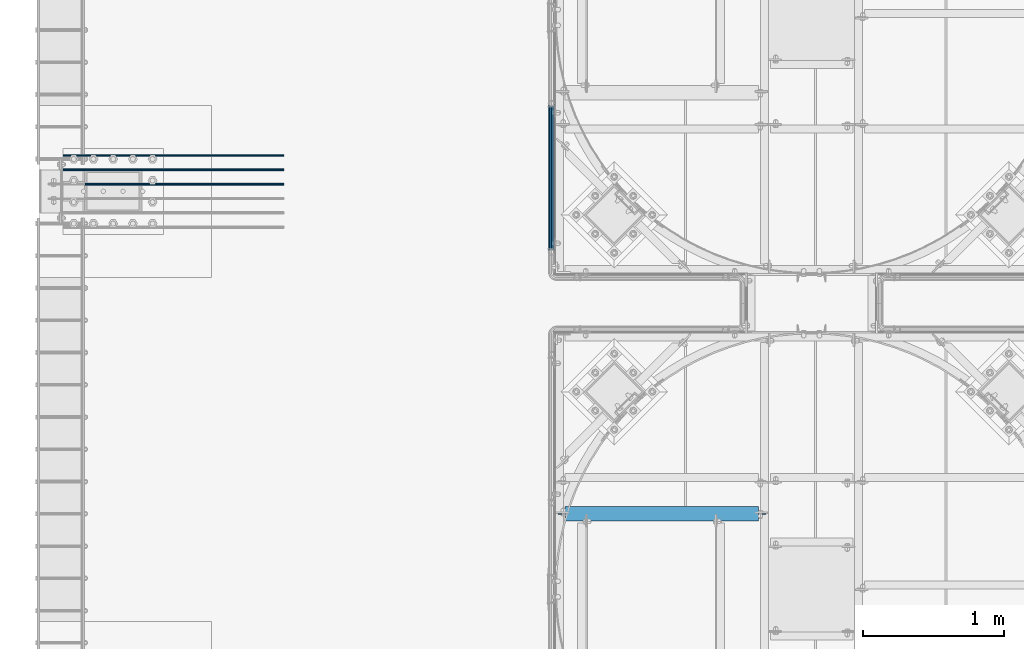
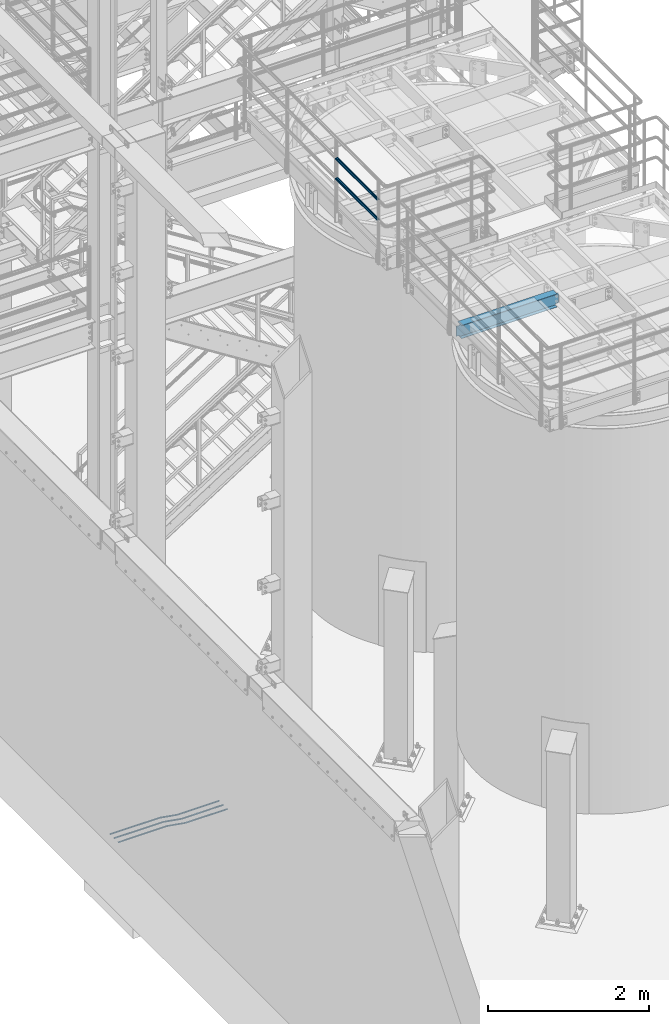
# One storey, part 918 of 1876: 6 beams, 3 elements without a shape of their own.
"""IFC2X3 building model written with IfcOpenShell, lengths in millimetres."""

import ifcopenshell
import ifcopenshell.guid

model = None  # the IFC model being written
_history = None  # IfcOwnerHistory: only IFC2X3 demands one
_inside = {}  # id of a spatial element -> (the spatial element, [elements in it])
_under = {}  # id of a project, library or spatial element -> (it, [spatial elements below it])
_declared = {}  # id of a project -> (the project, [libraries it declares])
_typed = {}  # id of a type object -> (the type object, [elements of that type])
_made_of = {}  # id of a material, layer set ... -> (it, [elements and type objects made of it])


def new_model(schema):
    """Start an empty IFC model of exactly this schema.

    Asked for "IFC4X3", IfcOpenShell would pick the latest addendum, in which some entities
    have other attributes; the version numbers below select the first issue.
    IFC2X3 requires an IfcOwnerHistory on every rooted entity: one is made here for all.
    """
    global model, _history
    if schema == "IFC4X3":
        model = ifcopenshell.file(schema_version=(4, 3, 0, 0))
    else:
        model = ifcopenshell.file(schema=schema)
    _inside.clear()
    _under.clear()
    _declared.clear()
    _typed.clear()
    _made_of.clear()
    _history = None
    if model.schema == "IFC2X3":
        org = make("IfcOrganization", Name="unknown")
        user = make(
            "IfcPersonAndOrganization",
            ThePerson=make("IfcPerson", FamilyName="unknown"),
            TheOrganization=org,
        )
        app = make(
            "IfcApplication",
            ApplicationDeveloper=org,
            Version="unknown",
            ApplicationFullName="unknown",
            ApplicationIdentifier="unknown",
        )
        _history = make(
            "IfcOwnerHistory",
            OwningUser=user,
            OwningApplication=app,
            ChangeAction="ADDED",
            CreationDate=0,
        )
    return model


def make(cls, **values):
    """One entity of the class cls with the attributes given. An attribute that is None is left unset."""
    return model.create_entity(
        cls, **{name: value for name, value in values.items() if value is not None}
    )


def rooted(cls, **values):
    """An entity with a GlobalId (a new one), such as an element, a storey or a relation."""
    return make(cls, GlobalId=ifcopenshell.guid.new(), OwnerHistory=_history, **values)


def si_unit(unit_type, name, prefix=None):
    """IfcSIUnit, for example si_unit("LENGTHUNIT", "METRE", prefix="MILLI")."""
    return make("IfcSIUnit", UnitType=unit_type, Prefix=prefix, Name=name)


def assignment(units):
    """IfcUnitAssignment: the units of a project."""
    return None if units is None else make("IfcUnitAssignment", Units=units)


def point(xyz):
    """IfcCartesianPoint."""
    return None if xyz is None else make("IfcCartesianPoint", Coordinates=xyz)


def direction(xyz):
    """IfcDirection."""
    return None if xyz is None else make("IfcDirection", DirectionRatios=xyz)


def frame(location, z_axis=None, x_axis=None):
    """IfcAxis2Placement3D, a coordinate frame: its origin and axes. An axis left out is left unset."""
    return make(
        "IfcAxis2Placement3D",
        Location=point(location),
        Axis=direction(z_axis),
        RefDirection=direction(x_axis),
    )


def origin_with_axes():
    """The frame at (0, 0, 0) with the z axis (0, 0, 1) and the x axis (1, 0, 0) written out."""
    return frame((0.0, 0.0, 0.0), z_axis=(0.0, 0.0, 1.0), x_axis=(1.0, 0.0, 0.0))


def place(relative_to, where):
    """IfcLocalPlacement: puts the frame where relative to a parent placement (None: the world)."""
    return make(
        "IfcLocalPlacement", PlacementRelTo=relative_to, RelativePlacement=where
    )


def context(
    kind, dimensions, precision=None, world=None, true_north=None, identifier=None
):
    """IfcGeometricRepresentationContext, for example the 3D "Model" context."""
    return make(
        "IfcGeometricRepresentationContext",
        ContextIdentifier=identifier,
        ContextType=kind,
        CoordinateSpaceDimension=dimensions,
        Precision=precision,
        WorldCoordinateSystem=world,
        TrueNorth=true_north,
    )


def subcontext(parent, identifier, kind, view, scale=None):
    """IfcGeometricRepresentationSubContext, for example "Body" below "Model"."""
    return make(
        "IfcGeometricRepresentationSubContext",
        ContextIdentifier=identifier,
        ContextType=kind,
        ParentContext=parent,
        TargetScale=scale,
        TargetView=view,
    )


def project(units=None, contexts=None):
    """IfcProject with its units and contexts."""
    return rooted(
        "IfcProject",
        Name="project",
        RepresentationContexts=contexts,
        UnitsInContext=assignment(units),
    )


def spatial(cls, under=None, at=None, **own):
    """A site, building, storey or space (cls), placed at a placement, below another one or the project."""
    s = rooted(cls, ObjectPlacement=at, **own)
    if under is not None:
        _under.setdefault(under.id(), (under, []))[1].append(s)
    return s


def faces_of(points, faces, orient=None, outer=None):
    """IfcFace entities. A face is a list of loops; a loop is a list of indices into points, from 0.

    orient and outer hold one flag for each loop. By default every Orientation is true, the
    first loop of a face is its IfcFaceOuterBound and the others are IfcFaceBound.
    """
    made = []
    for i, loops in enumerate(faces):
        bounds = []
        for j, loop in enumerate(loops):
            is_outer = j == 0 if outer is None else outer[i][j]
            bounds.append(
                make(
                    "IfcFaceOuterBound" if is_outer else "IfcFaceBound",
                    Bound=make("IfcPolyLoop", Polygon=[points[k] for k in loop]),
                    Orientation=True if orient is None else orient[i][j],
                )
            )
        made.append(make("IfcFace", Bounds=bounds))
    return made


def faceted_brep(points, faces, orient=None, outer=None, voids=None):
    """IfcFacetedBrep: a solid bounded by flat faces; with voids (closed shells), ...WithVoids."""
    shared = [point(p) for p in points]
    hull = make("IfcClosedShell", CfsFaces=faces_of(shared, faces, orient, outer))
    if voids is None:
        return make("IfcFacetedBrep", Outer=hull)
    return make(
        "IfcFacetedBrepWithVoids",
        Outer=hull,
        Voids=[
            make(cls, CfsFaces=faces_of(shared, fs, o, b)) for cls, fs, o, b in voids
        ],
    )


def shape(context_of_items, identifier, shape_type, items):
    """IfcShapeRepresentation: the items that make up one representation, for example the "Body"."""
    return make(
        "IfcShapeRepresentation",
        ContextOfItems=context_of_items,
        RepresentationIdentifier=identifier,
        RepresentationType=shape_type,
        Items=items,
    )


def material(Name=None, Category=None):
    """IfcMaterial."""
    return make("IfcMaterial", Name=Name, Category=Category)


def made_of(thing, what):
    """Note that an element or type object is made of a material, layer set ...; save() writes the relation."""
    if what is not None:
        _made_of.setdefault(what.id(), (what, []))[1].append(thing)
    return thing


def type_object(cls, material=None, **own):
    """A type object (cls), such as IfcWallType, which elements share."""
    return made_of(rooted(cls, **own), material)


def element(
    cls,
    number,
    at=None,
    inside=None,
    cuts=None,
    type_object=None,
    material=None,
    context=None,
    identifier="Body",
    shape_type=None,
    held_by="IfcProductDefinitionShape",
    body=None,
    shapes=None,
    **own,
):
    """One element of the class cls, such as IfcWall. Its Tag is "e" and its number.

    at: its placement. inside: the storey or other place that contains it. cuts: it is an
    opening in that element (IfcRelVoidsElement). A single representation is given by context,
    identifier, shape_type and body (its items); several are given by shapes. held_by: the class
    of the entity that holds the representations. save() writes the other relations.
    """
    e = rooted(cls, Tag="e%d" % number, ObjectPlacement=at, **own)
    if body is not None:
        shapes = [shape(context, identifier, shape_type, body)]
    if shapes is not None:
        e.Representation = make(held_by, Representations=shapes)
    if inside is not None:
        _inside.setdefault(inside.id(), (inside, []))[1].append(e)
    if cuts is not None:
        rooted(
            "IfcRelVoidsElement", RelatingBuildingElement=cuts, RelatedOpeningElement=e
        )
    if type_object is not None:
        _typed.setdefault(type_object.id(), (type_object, []))[1].append(e)
    return made_of(e, material)


def aggregate(whole, parts):
    """IfcRelAggregates: a whole, such as a stair, and the parts it consists of."""
    return rooted("IfcRelAggregates", RelatingObject=whole, RelatedObjects=parts)


def save(model, path):
    """Write the relations noted so far, then the file.

    IfcRelAggregates (storeys below a building ...), IfcRelContainedInSpatialStructure (elements
    in a storey), IfcRelDefinesByType, IfcRelAssociatesMaterial and IfcRelDeclares: one each for
    every whole, place, type object, material and project.
    """
    for whole, parts in _under.values():
        aggregate(whole, parts)
    for where, things in _inside.values():
        rooted(
            "IfcRelContainedInSpatialStructure",
            RelatedElements=things,
            RelatingStructure=where,
        )
    for kind, things in _typed.values():
        rooted("IfcRelDefinesByType", RelatedObjects=things, RelatingType=kind)
    for what, things in _made_of.values():
        rooted("IfcRelAssociatesMaterial", RelatedObjects=things, RelatingMaterial=what)
    for by, libraries in _declared.values():
        rooted("IfcRelDeclares", RelatingContext=by, RelatedDefinitions=libraries)
    model.write(path)


model = new_model("IFC2X3")

# Units and contexts
model_context = context("Model", 3, precision=1e-05, world=origin_with_axes())
body_context = subcontext(model_context, "Body", "Model", "MODEL_VIEW")
ifc_project = project(units=[si_unit("LENGTHUNIT", "METRE", prefix="MILLI"), si_unit("AREAUNIT", "SQUARE_METRE"), si_unit("VOLUMEUNIT", "CUBIC_METRE"), si_unit("MASSUNIT", "GRAM", prefix="KILO"), si_unit("TIMEUNIT", "SECOND"), si_unit("PLANEANGLEUNIT", "RADIAN"), si_unit("SOLIDANGLEUNIT", "STERADIAN"), si_unit("THERMODYNAMICTEMPERATUREUNIT", "DEGREE_CELSIUS"), si_unit("LUMINOUSINTENSITYUNIT", "LUMEN")], contexts=[model_context])

# Site, building, storey
site_placement = place(None, origin_with_axes())
site = spatial("IfcSite", under=ifc_project, at=site_placement, CompositionType="ELEMENT")
building_placement = place(site_placement, origin_with_axes())
building = spatial("IfcBuilding", under=site, at=building_placement, Name="Undefined", CompositionType="ELEMENT")
storey_placement = place(building_placement, origin_with_axes())
storey = spatial("IfcBuildingStorey", under=building, at=storey_placement, Name="Undefined", CompositionType="ELEMENT", Elevation=0.0)

# Assembly, beams
assembly_1_placement = place(storey_placement, origin_with_axes())
assembly_1 = element("IfcElementAssembly", 1, at=assembly_1_placement, inside=storey, Name="HANDRAIL", AssemblyPlace="NOTDEFINED", PredefinedType="RIGID_FRAME")
ifc_material_1 = material()
beam_type_1 = type_object("IfcBeamType", Name="PIPE1-1/4STD", PredefinedType="NOTDEFINED")
beam_1_placement = place(assembly_1_placement, frame((3338.07274593762, -11201.3643554687, 8480.425), z_axis=(0.0, 0.0, 1.0), x_axis=(0.0, 1.0, 0.0)))
beam_1 = element("IfcBeam", 2, at=beam_1_placement, type_object=beam_type_1, material=ifc_material_1, Name="RAIL", ObjectType="PIPE1-1/4STD", context=body_context, shape_type="Brep", body=[
    faceted_brep([(1035.84245243742, -10.5409999999993, 18.2575475625836), (1035.84245243742, -10.5409999999993, 13.3999612267253), (1035.36603877327, -8.76300000000083, 15.1779612267255), (1033.018, 0.0, 17.5259999999998), (1033.018, 0.0, 21.0820000000003), (1035.36603877327, 8.76300000000083, 15.1779612267255), (1035.84245243742, 10.5409999999993, 13.3999612267253), (1035.84245243742, 10.5409999999993, 18.2575475625836), (1054.1, 21.0820000000003, 0.0), (1043.559, 18.2575475625836, 10.5409999999993), (1043.559, 18.2575475625836, -10.5409999999993), (1040.47941366414, 15.1779612267255, 8.76300000000083), (1042.82745243742, 17.5259999999998, 0.0), (1040.47941366414, 15.1779612267255, -8.76300000000083), (1035.84245243742, 10.5409999999993, -13.3999612267253), (1035.84245243742, 10.5409999999993, -18.2575475625836), (1035.36603877327, 8.76300000000083, -15.1779612267255), (1033.018, 0.0, -17.5259999999998), (1033.018, 0.0, -21.0820000000003), (1035.84245243742, -10.5409999999993, -13.3999612267253), (1035.84245243742, -10.5409999999993, -18.2575475625836), (1035.36603877327, -8.76300000000083, -15.1779612267255), (1054.1, -21.0820000000003, 0.0), (1043.559, -18.2575475625836, -10.5409999999993), (1043.559, -18.2575475625836, 10.5409999999993), (1040.47941366414, -15.1779612267255, -8.76300000000083), (1042.82745243742, -17.5259999999998, 0.0), (1040.47941366414, -15.1779612267255, 8.76300000000083), (10.5409999957128, -18.2575475672238, -10.5409999999993), (18.2575475625817, -10.5410000000011, -18.2575475625836), (9.09494701772928e-13, 21.0820000000003, 0.0), (10.5409999957128, 18.2575475579433, -10.5409999999993), (10.5409999999983, 18.2575475625836, 10.5410000000011), (18.2575475625817, 10.5409999999993, 18.2575475625836), (21.0819999999985, 1.81898940354586e-12, 21.0820000000003), (18.2575475625817, 10.5409999999993, -18.2575475625836), (21.0819999999985, 0.0, -21.0819999999985), (21.0819999999985, 0.0, -17.5259999999998), (18.2575475625817, -10.5409999999974, -13.3999612267271), (18.7339612267233, -8.76300000000083, -15.1779612267255), (18.7339612267251, 8.76299999999901, -15.1779612267255), (18.2575475625817, 10.5410000000011, -13.3999612267235), (13.6205863358573, 15.1779612267255, -8.76299999999901), (11.2725475625839, 17.5259999999998, 0.0), (13.6205863358573, 15.1779612267255, 8.76300000000083), (18.2575475625817, 10.5410000000011, 13.3999612267253), (18.7339612267251, 8.76299999999901, 15.1779612267273), (21.0819999999985, 1.81898940354586e-12, 17.5259999999998), (18.7339612267233, -8.76300000000083, 15.1779612267273), (18.2575475625817, -10.5409999999974, 13.3999612267289), (18.2575475625817, -10.5410000000011, 18.2575475625836), (10.5409999999983, -18.2575475625836, 10.5410000000011), (9.09494701772928e-13, -21.0820000000003, 0.0), (13.6205863358537, -15.1779612267255, 8.76300000000083), (11.2725475625793, -17.5259999999998, 0.0), (13.6205863358537, -15.1779612267255, -8.76299999999901)], [[[0, 1, 2, 3, 4]], [[4, 3, 5, 6, 7]], [[8, 9, 10]], [[7, 6, 11, 12, 13, 14, 15, 10, 9]], [[16, 17, 18, 15, 14]], [[19, 20, 18, 17, 21]], [[22, 23, 24]], [[24, 23, 20, 19, 25, 26, 27, 1, 0]], [[28, 29, 20, 23]], [[30, 31, 32]], [[33, 34, 4, 7]], [[32, 33, 7, 9]], [[30, 32, 9, 8]], [[31, 30, 8, 10]], [[35, 31, 10, 15]], [[36, 35, 15, 18]], [[29, 36, 18, 20]], [[37, 36, 29, 38, 39]], [[40, 41, 35, 36, 37]], [[32, 31, 35, 41, 42, 43, 44, 45, 33]], [[33, 45, 46, 47, 34]], [[34, 47, 48, 49, 50]], [[34, 50, 0, 4]], [[50, 51, 24, 0]], [[51, 52, 22, 24]], [[52, 28, 23, 22]], [[51, 28, 52]], [[50, 49, 53, 54, 55, 38, 29, 28, 51]], [[55, 54, 26, 25]], [[21, 39, 38, 55, 25, 19]], [[37, 39, 21, 17]], [[40, 37, 17, 16]], [[42, 41, 40, 16, 14, 13]], [[43, 42, 13, 12]], [[44, 43, 12, 11]], [[5, 46, 45, 44, 11, 6]], [[47, 46, 5, 3]], [[48, 47, 3, 2]], [[53, 49, 48, 2, 1, 27]], [[54, 53, 27, 26]]]),
])
beam_2_placement = place(assembly_1_placement, frame((3338.07274593762, -10147.2643554687, 8785.225), z_axis=(0.0, 0.0, -1.0), x_axis=(0.0, -1.0, 0.0)))
beam_2 = element("IfcBeam", 3, at=beam_2_placement, type_object=beam_type_1, material=ifc_material_1, Name="RAIL", ObjectType="PIPE1-1/4STD", context=body_context, shape_type="Brep", body=[
    faceted_brep([(9.09494701772928e-13, 21.0820000000003, 0.0), (10.5409999957128, 18.2575475579433, -10.5409999999993), (10.5409999999983, 18.2575475625836, 10.5410000000011), (10.5409999999983, -18.2575475625836, 10.5410000000011), (10.5409999957128, -18.2575475672238, -10.5409999999993), (9.09494701772928e-13, -21.0820000000003, 0.0), (18.2575475625817, -10.5410000000011, 18.2575475625836), (18.2575475625817, -10.5409999999974, 13.3999612267289), (13.6205863358537, -15.1779612267255, 8.76300000000083), (11.2725475625793, -17.5259999999998, 0.0), (13.6205863358537, -15.1779612267255, -8.76299999999901), (18.2575475625817, -10.5409999999974, -13.3999612267271), (18.2575475625817, -10.5410000000011, -18.2575475625836), (21.0819999999985, 0.0, -17.5259999999998), (21.0819999999985, 0.0, -21.0819999999985), (18.7339612267233, -8.76300000000083, -15.1779612267255), (18.7339612267251, 8.76299999999901, -15.1779612267255), (18.2575475625817, 10.5410000000011, -13.3999612267235), (18.2575475625817, 10.5409999999993, -18.2575475625836), (13.6205863358573, 15.1779612267255, -8.76299999999901), (11.2725475625839, 17.5259999999998, 0.0), (13.6205863358573, 15.1779612267255, 8.76300000000083), (18.2575475625817, 10.5410000000011, 13.3999612267253), (18.2575475625817, 10.5409999999993, 18.2575475625836), (18.7339612267251, 8.76299999999901, 15.1779612267273), (21.0819999999985, 1.81898940354586e-12, 17.5259999999998), (21.0819999999985, 1.81898940354586e-12, 21.0820000000003), (18.7339612267233, -8.76300000000083, 15.1779612267273), (1054.1, 21.0820000000003, 0.0), (1043.559, 18.2575475625836, -10.5409999999993), (1035.84245243742, 10.5409999999993, -18.2575475625836), (1054.1, -21.0820000000003, 0.0), (1043.559, -18.2575475625836, -10.5409999999993), (1043.559, -18.2575475625836, 10.5409999999993), (1035.84245243742, -10.5409999999993, 18.2575475625836), (1035.84245243742, -10.5409999999993, -18.2575475625836), (1033.018, 0.0, -21.0820000000003), (1035.36603877327, 8.76300000000083, -15.1779612267255), (1033.018, 0.0, -17.5259999999998), (1035.84245243742, 10.5409999999993, -13.3999612267253), (1035.84245243742, -10.5409999999993, -13.3999612267253), (1035.36603877327, -8.76300000000083, -15.1779612267255), (1040.47941366414, -15.1779612267255, -8.76300000000083), (1042.82745243742, -17.5259999999998, 0.0), (1040.47941366414, -15.1779612267255, 8.76300000000083), (1035.84245243742, -10.5409999999993, 13.3999612267253), (1035.36603877327, -8.76300000000083, 15.1779612267255), (1033.018, 0.0, 17.5259999999998), (1033.018, 0.0, 21.0820000000003), (1035.84245243742, 10.5409999999993, 18.2575475625836), (1043.559, 18.2575475625836, 10.5409999999993), (1035.84245243742, 10.5409999999993, 13.3999612267253), (1040.47941366414, 15.1779612267255, 8.76300000000083), (1042.82745243742, 17.5259999999998, 0.0), (1040.47941366414, 15.1779612267255, -8.76300000000083), (1035.36603877327, 8.76300000000083, 15.1779612267255)], [[[0, 1, 2]], [[3, 4, 5]], [[6, 7, 8, 9, 10, 11, 12, 4, 3]], [[13, 14, 12, 11, 15]], [[16, 17, 18, 14, 13]], [[2, 1, 18, 17, 19, 20, 21, 22, 23]], [[23, 22, 24, 25, 26]], [[26, 25, 27, 7, 6]], [[1, 0, 28, 29]], [[18, 1, 29, 30]], [[31, 32, 33]], [[6, 3, 33, 34]], [[3, 5, 31, 33]], [[5, 4, 32, 31]], [[4, 12, 35, 32]], [[12, 14, 36, 35]], [[14, 18, 30, 36]], [[37, 38, 36, 30, 39]], [[40, 35, 36, 38, 41]], [[33, 32, 35, 40, 42, 43, 44, 45, 34]], [[34, 45, 46, 47, 48]], [[26, 6, 34, 48]], [[2, 23, 49, 50]], [[23, 26, 48, 49]], [[0, 2, 50, 28]], [[28, 50, 29]], [[49, 51, 52, 53, 54, 39, 30, 29, 50]], [[48, 47, 55, 51, 49]], [[25, 24, 55, 47]], [[55, 24, 22, 21, 52, 51]], [[21, 20, 53, 52]], [[20, 19, 54, 53]], [[19, 17, 16, 37, 39, 54]], [[16, 13, 38, 37]], [[13, 15, 41, 38]], [[41, 15, 11, 10, 42, 40]], [[10, 9, 43, 42]], [[9, 8, 44, 43]], [[8, 7, 27, 46, 45, 44]], [[27, 25, 47, 46]]]),
])
aggregate(assembly_1, [beam_1, beam_2])

# Assembly, beam
assembly_2_placement = place(storey_placement, origin_with_axes())
assembly_2 = element("IfcElementAssembly", 4, at=assembly_2_placement, inside=storey, Name="BEAM", AssemblyPlace="NOTDEFINED", PredefinedType="RIGID_FRAME")
ifc_material_2 = material(Name="STEEL/A992")
beam_type_2 = type_object("IfcBeamType", Name="W8X13", PredefinedType="NOTDEFINED")
beam_3_placement = place(assembly_2_placement, frame((3365.50143150122, -13055.5644042969, 7896.225), z_axis=(0.0, 0.0, 1.0), x_axis=(1.0, 0.0, 0.0)))
beam_3 = element("IfcBeam", 5, at=beam_3_placement, type_object=beam_type_2, material=ifc_material_2, Name="BEAM", ObjectType="W8X13", context=body_context, shape_type="Brep", body=[
    faceted_brep([(1441.45000056773, -3.17499999999927, -95.25), (1441.45000056773, -50.7999999999993, -95.25), (1441.45000056773, -50.7999999999993, -101.6), (1441.45000056773, 50.7999999999993, -101.6), (1441.45000056773, 50.7999999999993, -95.25), (1441.45000056773, 3.17499999999927, -95.25), (1441.45000056773, 3.17499999999927, -89.1599998092661), (1441.45000056773, -3.17499999999927, -89.1599998092661), (1442.41673049032, 3.17499999999927, -84.2999202912206), (1442.41673049032, -3.17499999999927, -84.2999202912206), (1445.1697443908, 3.17499999999927, -80.1797438230669), (1445.1697443908, -3.17499999999927, -80.1797438230669), (1449.28992085895, 3.17499999999927, -77.4267299225885), (1449.28992085895, -3.17499999999927, -77.4267299225885), (1454.150000377, 3.17499999999927, -76.4600000000009), (1454.150000377, -3.17499999999927, -76.4600000000009), (1492.25, -3.17499999999927, -76.4600000000009), (1492.25, 3.17499999999927, -76.4600000000009), (69.8500006943577, 3.17500000000018, 95.25), (69.8500006943577, 50.8000000000002, 95.25), (1441.45000056773, 50.7999999999993, 95.25), (1441.45000056773, 3.17499999999927, 95.25), (69.849999432266, -3.17499999999927, -89.1599998092643), (69.849999432266, 3.17499999999927, -89.1599998092643), (69.849999432266, 3.17499999999927, -95.25), (69.849999432266, 50.7999999999993, -95.25), (69.849999432266, 50.7999999999993, -101.6), (69.849999432266, -50.7999999999993, -101.6), (69.849999432266, -50.7999999999993, -95.25), (69.849999432266, -3.17499999999927, -95.25), (68.883269509678, -3.17499999999927, -84.2999202912188), (68.883269509678, 3.17499999999927, -84.2999202912188), (66.1302556092, -3.17499999999927, -80.1797438230651), (66.1302556092, 3.17499999999927, -80.1797438230651), (62.0100791410464, -3.17499999999927, -77.4267299225867), (62.0100791410464, 3.17499999999927, -77.4267299225867), (57.1499996230009, -3.17499999999927, -76.4599999999991), (57.1499996230009, 3.17499999999927, -76.4599999999991), (19.0499999999997, -3.17499999999927, -76.4599999999991), (19.0499999999997, 3.17499999999927, -76.4599999999991), (19.0499999999997, -3.17499999999927, 75.9400016784675), (19.0499999999997, 3.17499999999927, 75.9400016784675), (57.1499996230009, -3.17499999999927, 75.9400016784675), (57.1499996230009, 3.17499999999927, 75.9400016784675), (62.0100791410464, -3.17499999999927, 76.9067316010551), (62.0100791410464, 3.17499999999927, 76.9067316010551), (66.1302556092, -3.17499999999927, 79.6597455015335), (66.1302556092, 3.17499999999927, 79.6597455015335), (68.883269509678, -3.17499999999927, 83.7799219696872), (68.883269509678, 3.17499999999927, 83.7799219696872), (69.849999432266, -3.17499999999927, 88.6400014877327), (69.849999432266, 3.17499999999927, 88.6400014877327), (69.849999432266, -50.7999999999993, 101.6), (69.849999432266, 50.7999999999993, 101.6), (69.8500006943577, -3.17500000000018, 95.25), (69.8500006943577, -50.8000000000002, 95.25), (1441.45000056773, -3.17499999999927, 95.25), (1441.45000056773, -50.7999999999993, 95.25), (1441.45000056773, -50.7999999999993, 101.6), (1441.45000056773, 50.7999999999993, 101.6), (1441.45000056773, -3.17499999999927, 88.6400014877308), (1441.45000056773, 3.17499999999927, 88.6400014877308), (1442.41673049032, -3.17499999999927, 83.7799219696853), (1442.41673049032, 3.17499999999927, 83.7799219696853), (1445.1697443908, -3.17499999999927, 79.6597455015317), (1445.1697443908, 3.17499999999927, 79.6597455015317), (1449.28992085895, -3.17499999999927, 76.9067316010533), (1449.28992085895, 3.17499999999927, 76.9067316010533), (1454.150000377, -3.17499999999927, 75.9400016784657), (1454.150000377, 3.17499999999927, 75.9400016784657), (1492.25, -3.17499999999927, 75.9400016784657), (1492.25, 3.17499999999927, 75.9400016784657)], [[[0, 1, 2, 3, 4, 5, 6, 7]], [[7, 6, 8, 9]], [[9, 8, 10, 11]], [[11, 10, 12, 13]], [[13, 12, 14, 15]], [[16, 15, 14, 17]], [[18, 19, 20, 21]], [[22, 23, 24, 25, 26, 27, 28, 29]], [[30, 31, 23, 22]], [[32, 33, 31, 30]], [[34, 35, 33, 32]], [[36, 37, 35, 34]], [[38, 39, 37, 36]], [[40, 41, 39, 38]], [[42, 43, 41, 40]], [[44, 45, 43, 42]], [[46, 47, 45, 44]], [[48, 49, 47, 46]], [[50, 51, 49, 48]], [[52, 53, 19, 18, 51, 50, 54, 55]], [[55, 54, 56, 57]], [[52, 55, 57, 58]], [[53, 52, 58, 59]], [[19, 53, 59, 20]], [[58, 57, 56, 60, 61, 21, 20, 59]], [[62, 63, 61, 60]], [[64, 65, 63, 62]], [[66, 67, 65, 64]], [[68, 69, 67, 66]], [[70, 71, 69, 68]], [[71, 70, 16, 17]], [[12, 10, 8, 6, 5, 24, 23, 31, 33, 35, 37, 39, 41, 43, 45, 47, 49, 51, 18, 21, 61, 63, 65, 67, 69, 71, 17, 14]], [[25, 24, 5, 4]], [[26, 25, 4, 3]], [[27, 26, 3, 2]], [[28, 27, 2, 1]], [[29, 28, 1, 0]], [[70, 68, 66, 64, 62, 60, 56, 54, 50, 48, 46, 44, 42, 40, 38, 36, 34, 32, 30, 22, 29, 0, 7, 9, 11, 13, 15, 16]]]),
])
aggregate(assembly_2, [beam_3])

# Assembly, beams
assembly_3_placement = place(storey_placement, origin_with_axes())
assembly_3 = element("IfcElementAssembly", 6, at=assembly_3_placement, inside=storey, Name="PLATE", AssemblyPlace="NOTDEFINED", PredefinedType="RIGID_FRAME")
ifc_material_3 = material(Name="STEEL/A706-GR.60")
beam_type_3 = type_object("IfcBeamType", Name="5 REBAR", PredefinedType="NOTDEFINED")
beam_4_placement = place(assembly_3_placement, frame((-123.825012207031, -10718.799991862, -58.7375000000029), z_axis=(0.0, 1.0, 0.0), x_axis=(1.0, 0.0, 0.0)))
beam_4 = element("IfcBeam", 7, at=beam_4_placement, type_object=beam_type_3, material=ifc_material_3, Name="REBAR", ObjectType="5 REBAR", context=body_context, shape_type="Brep", body=[
    faceted_brep([(0.0, -7.9375, 0.0), (0.0, -5.61266007566822, -5.61266007566883), (710.034986674476, -5.61266007566822, -5.61266007566883), (710.034986674476, -7.9375, 0.0), (0.0, 0.0, -7.9375), (710.034986674476, 0.0, -7.9375), (0.0, 5.61266007566822, -5.61266007566883), (710.034986674476, 5.61266007566822, -5.61266007566883), (0.0, 7.9375, 0.0), (710.034986674476, 7.9375, 0.0), (0.0, 5.61266007566822, 5.61266007566883), (710.034986674476, 5.61266007566822, 5.61266007566883), (0.0, 0.0, 7.9375), (710.034986674476, 0.0, 7.9375), (0.0, -5.61266007566822, 5.61266007566883), (710.034986674476, -5.61266007566822, 5.61266007566883), (711.670256270764, -5.61266007566822, -5.61266007566883), (711.865037739587, -7.9375, 0.0), (711.200012207031, 0.0, -7.9375), (710.729768143299, 5.61266007566822, -5.61266007566883), (710.534986674476, 7.9375, 0.0), (710.729768143299, 5.61266007566822, 5.61266007566883), (711.200012207031, 0.0, 7.9375), (711.670256270764, -5.61266007566822, 5.61266007566883), (713.282728188834, -5.34055537895146, -5.61266007566883), (713.669575632193, -7.63298416286913, 0.0), (712.34879584451, 0.193857281957023, -7.9375), (711.414863500185, 5.72826994286551, -5.61266007566883), (711.028016056827, 8.02069872678318, 0.0), (711.414863500185, 5.72826994286551, 5.61266007566883), (712.34879584451, 0.193857281957023, 7.9375), (713.282728188834, -5.34055537895146, 5.61266007566883), (964.985099878721, 37.1342292941951, -5.61266007566883), (965.371947322079, 34.8418005102774, 0.0), (964.051167534397, 42.6686419551035, -7.9375), (963.117235190072, 48.203054616012, -5.61266007566883), (962.730387746714, 50.4954833999297, 0.0), (963.117235190072, 48.203054616012, 5.61266007566883), (964.051167534397, 42.6686419551035, 7.9375), (964.985099878721, 37.1342292941951, 5.61266007566883), (965.670195235607, 37.2498391613923, -5.61266007566883), (965.864976704431, 34.9249992370606, 0.0), (965.199951171875, 42.8624992370605, -7.9375), (964.729707108143, 48.4751593127287, -5.61266007566883), (964.534925639319, 50.7999992370605, 0.0), (964.729707108143, 48.4751593127287, 5.61266007566883), (965.199951171875, 42.8624992370605, 7.9375), (965.670195235607, 37.2498391613923, 5.61266007566883), (966.36497670443, 37.2498391613923, -5.61266007566883), (966.36497670443, 34.9249992370605, 0.0), (966.36497670443, 42.8624992370605, -7.9375), (966.36497670443, 48.4751593127288, -5.61266007566883), (966.36497670443, 50.7999992370605, 0.0), (966.36497670443, 48.4751593127288, 5.61266007566883), (966.36497670443, 42.8624992370605, 7.9375), (966.36497670443, 37.2498391613923, 5.61266007566883), (1566.86254882812, 37.2498391613923, -5.61266007566883), (1566.86254882812, 34.9249992370605, 0.0), (1566.86254882812, 42.8624992370605, -7.9375), (1566.86254882812, 48.4751593127288, -5.61266007566883), (1566.86254882812, 50.7999992370605, 0.0), (1566.86254882812, 48.4751593127288, 5.61266007566883), (1566.86254882812, 42.8624992370605, 7.9375), (1566.86254882812, 37.2498391613923, 5.61266007566883)], [[[0, 1, 2, 3]], [[1, 4, 5, 2]], [[4, 6, 7, 5]], [[6, 8, 9, 7]], [[8, 10, 11, 9]], [[10, 12, 13, 11]], [[12, 14, 15, 13]], [[14, 0, 3, 15]], [[14, 12, 10, 8, 6, 4, 1, 0]], [[3, 2, 16, 17]], [[2, 5, 18, 16]], [[5, 7, 19, 18]], [[7, 9, 20, 19]], [[9, 11, 21, 20]], [[11, 13, 22, 21]], [[13, 15, 23, 22]], [[15, 3, 17, 23]], [[17, 16, 24, 25]], [[16, 18, 26, 24]], [[18, 19, 27, 26]], [[19, 20, 28, 27]], [[20, 21, 29, 28]], [[21, 22, 30, 29]], [[22, 23, 31, 30]], [[23, 17, 25, 31]], [[25, 24, 32, 33]], [[24, 26, 34, 32]], [[26, 27, 35, 34]], [[27, 28, 36, 35]], [[28, 29, 37, 36]], [[29, 30, 38, 37]], [[30, 31, 39, 38]], [[31, 25, 33, 39]], [[33, 32, 40, 41]], [[32, 34, 42, 40]], [[34, 35, 43, 42]], [[35, 36, 44, 43]], [[36, 37, 45, 44]], [[37, 38, 46, 45]], [[38, 39, 47, 46]], [[39, 33, 41, 47]], [[41, 40, 48, 49]], [[40, 42, 50, 48]], [[42, 43, 51, 50]], [[43, 44, 52, 51]], [[44, 45, 53, 52]], [[45, 46, 54, 53]], [[46, 47, 55, 54]], [[47, 41, 49, 55]], [[49, 48, 56, 57]], [[48, 50, 58, 56]], [[50, 51, 59, 58]], [[51, 52, 60, 59]], [[52, 53, 61, 60]], [[53, 54, 62, 61]], [[54, 55, 63, 62]], [[55, 49, 57, 63]], [[58, 59, 60, 61, 62, 63, 57, 56]]]),
])
beam_5_placement = place(assembly_3_placement, frame((-123.825012207031, -10617.199991862, -58.7375000000029), z_axis=(0.0, 1.0, 0.0), x_axis=(1.0, 0.0, 0.0)))
beam_5 = element("IfcBeam", 8, at=beam_5_placement, type_object=beam_type_3, material=ifc_material_3, Name="REBAR", ObjectType="5 REBAR", context=body_context, shape_type="Brep", body=[
    faceted_brep([(0.0, -7.9375, 0.0), (0.0, -5.61266007566822, -5.61266007566883), (710.034986674476, -5.61266007566822, -5.61266007566883), (710.034986674476, -7.9375, 0.0), (0.0, 0.0, -7.9375), (710.034986674476, 0.0, -7.9375), (0.0, 5.61266007566822, -5.61266007566883), (710.034986674476, 5.61266007566822, -5.61266007566883), (0.0, 7.9375, 0.0), (710.034986674476, 7.9375, 0.0), (0.0, 5.61266007566822, 5.61266007566883), (710.034986674476, 5.61266007566822, 5.61266007566883), (0.0, 0.0, 7.9375), (710.034986674476, 0.0, 7.9375), (0.0, -5.61266007566822, 5.61266007566883), (710.034986674476, -5.61266007566822, 5.61266007566883), (711.670256270764, -5.61266007566822, -5.61266007566883), (711.865037739587, -7.9375, 0.0), (711.200012207031, 0.0, -7.9375), (710.729768143299, 5.61266007566822, -5.61266007566883), (710.534986674476, 7.9375, 0.0), (710.729768143299, 5.61266007566822, 5.61266007566883), (711.200012207031, 0.0, 7.9375), (711.670256270764, -5.61266007566822, 5.61266007566883), (713.282728188834, -5.34055537895146, -5.61266007566883), (713.669575632193, -7.63298416286913, 0.0), (712.34879584451, 0.193857281957023, -7.9375), (711.414863500185, 5.72826994286551, -5.61266007566883), (711.028016056827, 8.02069872678318, 0.0), (711.414863500185, 5.72826994286551, 5.61266007566883), (712.34879584451, 0.193857281957023, 7.9375), (713.282728188834, -5.34055537895146, 5.61266007566883), (964.985099878721, 37.1342292941951, -5.61266007566883), (965.371947322079, 34.8418005102774, 0.0), (964.051167534397, 42.6686419551035, -7.9375), (963.117235190072, 48.203054616012, -5.61266007566883), (962.730387746714, 50.4954833999297, 0.0), (963.117235190072, 48.203054616012, 5.61266007566883), (964.051167534397, 42.6686419551035, 7.9375), (964.985099878721, 37.1342292941951, 5.61266007566883), (965.670195235607, 37.2498391613923, -5.61266007566883), (965.864976704431, 34.9249992370606, 0.0), (965.199951171875, 42.8624992370605, -7.9375), (964.729707108143, 48.4751593127287, -5.61266007566883), (964.534925639319, 50.7999992370605, 0.0), (964.729707108143, 48.4751593127287, 5.61266007566883), (965.199951171875, 42.8624992370605, 7.9375), (965.670195235607, 37.2498391613923, 5.61266007566883), (966.36497670443, 37.2498391613923, -5.61266007566883), (966.36497670443, 34.9249992370605, 0.0), (966.36497670443, 42.8624992370605, -7.9375), (966.36497670443, 48.4751593127288, -5.61266007566883), (966.36497670443, 50.7999992370605, 0.0), (966.36497670443, 48.4751593127288, 5.61266007566883), (966.36497670443, 42.8624992370605, 7.9375), (966.36497670443, 37.2498391613923, 5.61266007566883), (1566.86254882812, 37.2498391613923, -5.61266007566883), (1566.86254882812, 34.9249992370605, 0.0), (1566.86254882812, 42.8624992370605, -7.9375), (1566.86254882812, 48.4751593127288, -5.61266007566883), (1566.86254882812, 50.7999992370605, 0.0), (1566.86254882812, 48.4751593127288, 5.61266007566883), (1566.86254882812, 42.8624992370605, 7.9375), (1566.86254882812, 37.2498391613923, 5.61266007566883)], [[[0, 1, 2, 3]], [[1, 4, 5, 2]], [[4, 6, 7, 5]], [[6, 8, 9, 7]], [[8, 10, 11, 9]], [[10, 12, 13, 11]], [[12, 14, 15, 13]], [[14, 0, 3, 15]], [[14, 12, 10, 8, 6, 4, 1, 0]], [[3, 2, 16, 17]], [[2, 5, 18, 16]], [[5, 7, 19, 18]], [[7, 9, 20, 19]], [[9, 11, 21, 20]], [[11, 13, 22, 21]], [[13, 15, 23, 22]], [[15, 3, 17, 23]], [[17, 16, 24, 25]], [[16, 18, 26, 24]], [[18, 19, 27, 26]], [[19, 20, 28, 27]], [[20, 21, 29, 28]], [[21, 22, 30, 29]], [[22, 23, 31, 30]], [[23, 17, 25, 31]], [[25, 24, 32, 33]], [[24, 26, 34, 32]], [[26, 27, 35, 34]], [[27, 28, 36, 35]], [[28, 29, 37, 36]], [[29, 30, 38, 37]], [[30, 31, 39, 38]], [[31, 25, 33, 39]], [[33, 32, 40, 41]], [[32, 34, 42, 40]], [[34, 35, 43, 42]], [[35, 36, 44, 43]], [[36, 37, 45, 44]], [[37, 38, 46, 45]], [[38, 39, 47, 46]], [[39, 33, 41, 47]], [[41, 40, 48, 49]], [[40, 42, 50, 48]], [[42, 43, 51, 50]], [[43, 44, 52, 51]], [[44, 45, 53, 52]], [[45, 46, 54, 53]], [[46, 47, 55, 54]], [[47, 41, 49, 55]], [[49, 48, 56, 57]], [[48, 50, 58, 56]], [[50, 51, 59, 58]], [[51, 52, 60, 59]], [[52, 53, 61, 60]], [[53, 54, 62, 61]], [[54, 55, 63, 62]], [[55, 49, 57, 63]], [[58, 59, 60, 61, 62, 63, 57, 56]]]),
])
beam_6_placement = place(assembly_3_placement, frame((-123.825012207031, -10515.6, -58.7374999999993), z_axis=(0.0, 1.0, 0.0), x_axis=(1.0, 0.0, 0.0)))
beam_6 = element("IfcBeam", 9, at=beam_6_placement, type_object=beam_type_3, material=ifc_material_3, Name="REBAR", ObjectType="5 REBAR", context=body_context, shape_type="Brep", body=[
    faceted_brep([(0.0, -7.9375, 0.0), (0.0, -5.61266007566822, -5.61266007566883), (710.034986674476, -5.61266007566822, -5.61266007566883), (710.034986674476, -7.9375, 0.0), (0.0, 0.0, -7.9375), (710.034986674476, 0.0, -7.9375), (0.0, 5.61266007566822, -5.61266007566883), (710.034986674476, 5.61266007566822, -5.61266007566883), (0.0, 7.9375, 0.0), (710.034986674476, 7.9375, 0.0), (0.0, 5.61266007566822, 5.61266007566883), (710.034986674476, 5.61266007566822, 5.61266007566883), (0.0, 0.0, 7.9375), (710.034986674476, 0.0, 7.9375), (0.0, -5.61266007566822, 5.61266007566883), (710.034986674476, -5.61266007566822, 5.61266007566883), (711.670256270764, -5.61266007566822, -5.61266007566883), (711.865037739587, -7.9375, 0.0), (711.200012207031, 0.0, -7.9375), (710.729768143299, 5.61266007566822, -5.61266007566883), (710.534986674476, 7.9375, 0.0), (710.729768143299, 5.61266007566822, 5.61266007566883), (711.200012207031, 0.0, 7.9375), (711.670256270764, -5.61266007566822, 5.61266007566883), (713.282728188834, -5.34055537895146, -5.61266007566883), (713.669575632193, -7.63298416286913, 0.0), (712.34879584451, 0.193857281957023, -7.9375), (711.414863500185, 5.72826994286551, -5.61266007566883), (711.028016056827, 8.02069872678318, 0.0), (711.414863500185, 5.72826994286551, 5.61266007566883), (712.34879584451, 0.193857281957023, 7.9375), (713.282728188834, -5.34055537895146, 5.61266007566883), (964.985099878721, 37.1342292941951, -5.61266007566883), (965.371947322079, 34.8418005102774, 0.0), (964.051167534397, 42.6686419551035, -7.9375), (963.117235190072, 48.203054616012, -5.61266007566883), (962.730387746714, 50.4954833999297, 0.0), (963.117235190072, 48.203054616012, 5.61266007566883), (964.051167534397, 42.6686419551035, 7.9375), (964.985099878721, 37.1342292941951, 5.61266007566883), (965.670195235607, 37.2498391613923, -5.61266007566883), (965.864976704431, 34.9249992370606, 0.0), (965.199951171875, 42.8624992370605, -7.9375), (964.729707108143, 48.4751593127287, -5.61266007566883), (964.534925639319, 50.7999992370605, 0.0), (964.729707108143, 48.4751593127287, 5.61266007566883), (965.199951171875, 42.8624992370605, 7.9375), (965.670195235607, 37.2498391613923, 5.61266007566883), (966.36497670443, 37.2498391613923, -5.61266007566883), (966.36497670443, 34.9249992370605, 0.0), (966.36497670443, 42.8624992370605, -7.9375), (966.36497670443, 48.4751593127288, -5.61266007566883), (966.36497670443, 50.7999992370605, 0.0), (966.36497670443, 48.4751593127288, 5.61266007566883), (966.36497670443, 42.8624992370605, 7.9375), (966.36497670443, 37.2498391613923, 5.61266007566883), (1566.86254882812, 37.2498391613923, -5.61266007566883), (1566.86254882812, 34.9249992370605, 0.0), (1566.86254882812, 42.8624992370605, -7.9375), (1566.86254882812, 48.4751593127288, -5.61266007566883), (1566.86254882812, 50.7999992370605, 0.0), (1566.86254882812, 48.4751593127288, 5.61266007566883), (1566.86254882812, 42.8624992370605, 7.9375), (1566.86254882812, 37.2498391613923, 5.61266007566883)], [[[0, 1, 2, 3]], [[1, 4, 5, 2]], [[4, 6, 7, 5]], [[6, 8, 9, 7]], [[8, 10, 11, 9]], [[10, 12, 13, 11]], [[12, 14, 15, 13]], [[14, 0, 3, 15]], [[14, 12, 10, 8, 6, 4, 1, 0]], [[3, 2, 16, 17]], [[2, 5, 18, 16]], [[5, 7, 19, 18]], [[7, 9, 20, 19]], [[9, 11, 21, 20]], [[11, 13, 22, 21]], [[13, 15, 23, 22]], [[15, 3, 17, 23]], [[17, 16, 24, 25]], [[16, 18, 26, 24]], [[18, 19, 27, 26]], [[19, 20, 28, 27]], [[20, 21, 29, 28]], [[21, 22, 30, 29]], [[22, 23, 31, 30]], [[23, 17, 25, 31]], [[25, 24, 32, 33]], [[24, 26, 34, 32]], [[26, 27, 35, 34]], [[27, 28, 36, 35]], [[28, 29, 37, 36]], [[29, 30, 38, 37]], [[30, 31, 39, 38]], [[31, 25, 33, 39]], [[33, 32, 40, 41]], [[32, 34, 42, 40]], [[34, 35, 43, 42]], [[35, 36, 44, 43]], [[36, 37, 45, 44]], [[37, 38, 46, 45]], [[38, 39, 47, 46]], [[39, 33, 41, 47]], [[41, 40, 48, 49]], [[40, 42, 50, 48]], [[42, 43, 51, 50]], [[43, 44, 52, 51]], [[44, 45, 53, 52]], [[45, 46, 54, 53]], [[46, 47, 55, 54]], [[47, 41, 49, 55]], [[49, 48, 56, 57]], [[48, 50, 58, 56]], [[50, 51, 59, 58]], [[51, 52, 60, 59]], [[52, 53, 61, 60]], [[53, 54, 62, 61]], [[54, 55, 63, 62]], [[55, 49, 57, 63]], [[58, 59, 60, 61, 62, 63, 57, 56]]]),
])
aggregate(assembly_3, [beam_4, beam_5, beam_6])

save(model, "model.ifc")
